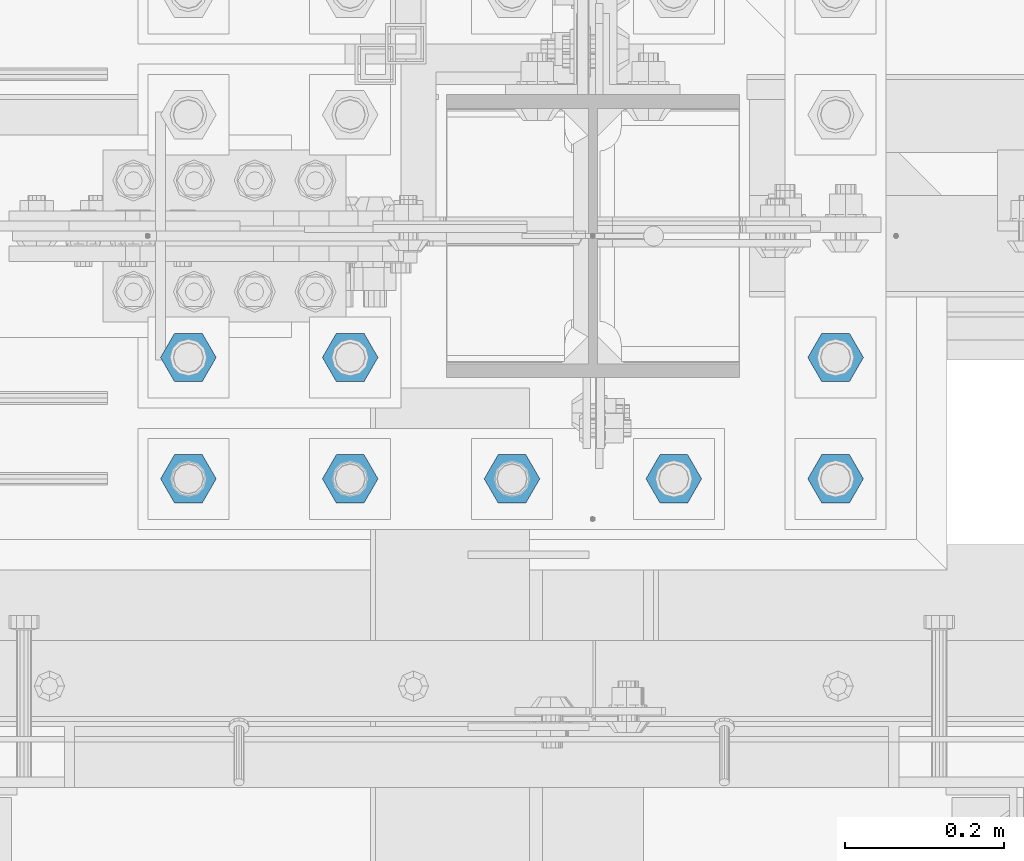
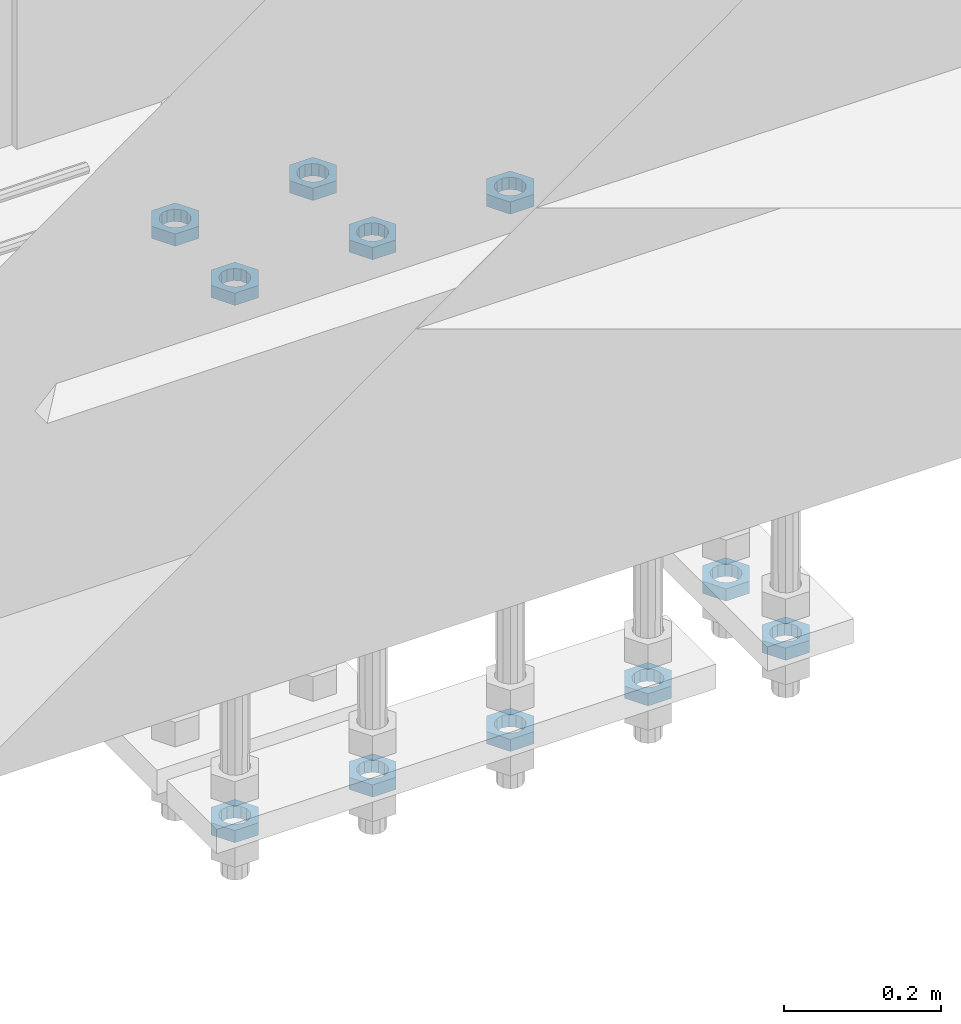
# One storey, part 2814 of 3843: 11 beams, 1 element without a shape of its own.
"""IFC2X3 building model written with IfcOpenShell, lengths in millimetres."""

from ifc_helpers import new_model, si_unit, frame, origin_with_axes, place, context, subcontext, project, spatial, faceted_brep, material, type_object, element, aggregate, save


model = new_model("IFC2X3")

# Units and contexts
model_context = context("Model", 3, precision=1e-05, world=origin_with_axes())
body_context = subcontext(model_context, "Body", "Model", "MODEL_VIEW")
ifc_project = project(units=[si_unit("LENGTHUNIT", "METRE", prefix="MILLI"), si_unit("AREAUNIT", "SQUARE_METRE"), si_unit("VOLUMEUNIT", "CUBIC_METRE"), si_unit("MASSUNIT", "GRAM", prefix="KILO"), si_unit("TIMEUNIT", "SECOND"), si_unit("PLANEANGLEUNIT", "RADIAN"), si_unit("SOLIDANGLEUNIT", "STERADIAN"), si_unit("THERMODYNAMICTEMPERATUREUNIT", "DEGREE_CELSIUS"), si_unit("LUMINOUSINTENSITYUNIT", "LUMEN")], contexts=[model_context])

# Site, building, storey
site_placement = place(None, origin_with_axes())
site = spatial("IfcSite", under=ifc_project, at=site_placement, CompositionType="ELEMENT")
building_placement = place(site_placement, origin_with_axes())
building = spatial("IfcBuilding", under=site, at=building_placement, Name="Undefined", CompositionType="ELEMENT")
storey_placement = place(building_placement, origin_with_axes())
storey = spatial("IfcBuildingStorey", under=building, at=storey_placement, Name="Undefined", CompositionType="ELEMENT", Elevation=0.0)

# Assembly, beams
assembly_placement = place(storey_placement, origin_with_axes())
assembly = element("IfcElementAssembly", 1, at=assembly_placement, inside=storey, Name="TEMPLATE", AssemblyPlace="NOTDEFINED", PredefinedType="RIGID_FRAME")
ifc_material = material(Name="STEEL/A572-50")
beam_type = type_object("IfcBeamType", Name="1-1/2_HALF_NUT", PredefinedType="NOTDEFINED")
beam_1_placement = place(assembly_placement, frame((48895.0, 25311.1, 29603.7), z_axis=(0.0, -1.0, 0.0), x_axis=(0.0, 0.0, -1.0)))
beam_1 = element("IfcBeam", 2, at=beam_1_placement, type_object=beam_type, material=ifc_material, Name="NUT", ObjectType="1-1/2_HALF_NUT", context=body_context, shape_type="Brep", body=[
    faceted_brep([(0.0, -34.9199981689453, 0.0), (0.0, -17.4599990844727, -30.25), (19.0500000000029, -17.4599990844727, -30.25), (19.0500000000029, -34.9199981689453, 0.0), (0.0, 17.4599990844727, -30.25), (19.0500000000029, 17.4599990844727, -30.25), (0.0, 34.9199981689453, 0.0), (19.0500000000029, 34.9199981689453, 0.0), (0.0, 17.4599990844727, 30.25), (19.0500000000029, 17.4599990844727, 30.25), (0.0, -17.4599990844727, 30.25), (19.0500000000029, -17.4599990844727, 30.25), (0.0, 0.0, 20.6399993896484), (0.0, 8.9553601105581, 18.5959968835959), (19.0500000000029, 8.95536011056538, 18.5959968835959), (19.0500000000029, 0.0, 20.6399993896484), (0.0, 16.1370013209525, 12.8688291298167), (19.0500000000029, 16.1370013209489, 12.8688291298167), (0.0, 20.1225115123816, 4.59283194104501), (19.0500000000029, 20.1225115123852, 4.59283194104501), (0.0, 20.1225115123816, -4.59283194104501), (19.0500000000029, 20.1225115123852, -4.59283194104501), (0.0, 16.1370013209525, -12.8688291298167), (19.0500000000029, 16.1370013209489, -12.8688291298167), (0.0, 8.9553601105581, -18.5959968835959), (19.0500000000029, 8.95536011056538, -18.5959968835959), (0.0, 0.0, -20.6399993896484), (19.0500000000029, 0.0, -20.6399993896484), (0.0, -8.9553601105581, -18.5959968835959), (19.0500000000029, -8.95536011056538, -18.5959968835959), (0.0, -16.1370013209525, -12.8688291298167), (19.0500000000029, -16.1370013209489, -12.8688291298167), (0.0, -20.1225115123816, -4.59283194104501), (19.0500000000029, -20.1225115123852, -4.59283194104501), (0.0, -20.1225115123816, 4.59283194104501), (19.0500000000029, -20.1225115123852, 4.59283194104501), (0.0, -16.1370013209525, 12.8688291298167), (19.0500000000029, -16.1370013209489, 12.8688291298167), (0.0, -8.9553601105581, 18.5959968835959), (19.0500000000029, -8.95536011056538, 18.5959968835959)], [[[0, 1, 2, 3]], [[1, 4, 5, 2]], [[4, 6, 7, 5]], [[6, 8, 9, 7]], [[8, 10, 11, 9]], [[10, 0, 3, 11]], [[12, 13, 14, 15]], [[13, 16, 17, 14]], [[16, 18, 19, 17]], [[18, 20, 21, 19]], [[20, 22, 23, 21]], [[22, 24, 25, 23]], [[24, 26, 27, 25]], [[26, 28, 29, 27]], [[28, 30, 31, 29]], [[30, 32, 33, 31]], [[32, 34, 35, 33]], [[34, 36, 37, 35]], [[36, 38, 39, 37]], [[38, 12, 15, 39]], [[5, 7, 9, 11, 3, 2], [17, 19, 21, 23, 25, 27, 29, 31, 33, 35, 37, 39, 15, 14]], [[10, 8, 6, 4, 1, 0], [38, 36, 34, 32, 30, 28, 26, 24, 22, 20, 18, 16, 13, 12]]]),
])
beam_2_placement = place(assembly_placement, frame((48691.8, 25463.5, 29603.7), z_axis=(0.0, -1.0, 0.0), x_axis=(0.0, 0.0, -1.0)))
beam_2 = element("IfcBeam", 3, at=beam_2_placement, type_object=beam_type, material=ifc_material, Name="NUT", ObjectType="1-1/2_HALF_NUT", context=body_context, shape_type="Brep", body=[
    faceted_brep([(0.0, -34.9199981689453, 0.0), (0.0, -17.4599990844727, -30.25), (19.0500000000029, -17.4599990844727, -30.25), (19.0500000000029, -34.9199981689453, 0.0), (0.0, 17.4599990844727, -30.25), (19.0500000000029, 17.4599990844727, -30.25), (0.0, 34.9199981689453, 0.0), (19.0500000000029, 34.9199981689453, 0.0), (0.0, 17.4599990844727, 30.25), (19.0500000000029, 17.4599990844727, 30.25), (0.0, -17.4599990844727, 30.25), (19.0500000000029, -17.4599990844727, 30.25), (0.0, 0.0, 20.6399993896484), (0.0, 8.9553601105581, 18.5959968835959), (19.0500000000029, 8.95536011056538, 18.5959968835959), (19.0500000000029, 0.0, 20.6399993896484), (0.0, 16.1370013209525, 12.8688291298167), (19.0500000000029, 16.1370013209489, 12.8688291298167), (0.0, 20.1225115123816, 4.59283194104501), (19.0500000000029, 20.1225115123852, 4.59283194104501), (0.0, 20.1225115123816, -4.59283194104501), (19.0500000000029, 20.1225115123852, -4.59283194104501), (0.0, 16.1370013209525, -12.8688291298167), (19.0500000000029, 16.1370013209489, -12.8688291298167), (0.0, 8.9553601105581, -18.5959968835959), (19.0500000000029, 8.95536011056538, -18.5959968835959), (0.0, 0.0, -20.6399993896484), (19.0500000000029, 0.0, -20.6399993896484), (0.0, -8.9553601105581, -18.5959968835959), (19.0500000000029, -8.95536011056538, -18.5959968835959), (0.0, -16.1370013209525, -12.8688291298167), (19.0500000000029, -16.1370013209489, -12.8688291298167), (0.0, -20.1225115123816, -4.59283194104501), (19.0500000000029, -20.1225115123852, -4.59283194104501), (0.0, -20.1225115123816, 4.59283194104501), (19.0500000000029, -20.1225115123852, 4.59283194104501), (0.0, -16.1370013209525, 12.8688291298167), (19.0500000000029, -16.1370013209489, 12.8688291298167), (0.0, -8.9553601105581, 18.5959968835959), (19.0500000000029, -8.95536011056538, 18.5959968835959)], [[[0, 1, 2, 3]], [[1, 4, 5, 2]], [[4, 6, 7, 5]], [[6, 8, 9, 7]], [[8, 10, 11, 9]], [[10, 0, 3, 11]], [[12, 13, 14, 15]], [[13, 16, 17, 14]], [[16, 18, 19, 17]], [[18, 20, 21, 19]], [[20, 22, 23, 21]], [[22, 24, 25, 23]], [[24, 26, 27, 25]], [[26, 28, 29, 27]], [[28, 30, 31, 29]], [[30, 32, 33, 31]], [[32, 34, 35, 33]], [[34, 36, 37, 35]], [[36, 38, 39, 37]], [[38, 12, 15, 39]], [[5, 7, 9, 11, 3, 2], [17, 19, 21, 23, 25, 27, 29, 31, 33, 35, 37, 39, 15, 14]], [[10, 8, 6, 4, 1, 0], [38, 36, 34, 32, 30, 28, 26, 24, 22, 20, 18, 16, 13, 12]]]),
])
beam_3_placement = place(assembly_placement, frame((48691.8, 25311.1, 29603.7), z_axis=(0.0, -1.0, 0.0), x_axis=(0.0, 0.0, -1.0)))
beam_3 = element("IfcBeam", 4, at=beam_3_placement, type_object=beam_type, material=ifc_material, Name="NUT", ObjectType="1-1/2_HALF_NUT", context=body_context, shape_type="Brep", body=[
    faceted_brep([(0.0, -34.9199981689453, 0.0), (0.0, -17.4599990844727, -30.25), (19.0500000000029, -17.4599990844727, -30.25), (19.0500000000029, -34.9199981689453, 0.0), (0.0, 17.4599990844727, -30.25), (19.0500000000029, 17.4599990844727, -30.25), (0.0, 34.9199981689453, 0.0), (19.0500000000029, 34.9199981689453, 0.0), (0.0, 17.4599990844727, 30.25), (19.0500000000029, 17.4599990844727, 30.25), (0.0, -17.4599990844727, 30.25), (19.0500000000029, -17.4599990844727, 30.25), (0.0, 0.0, 20.6399993896484), (0.0, 8.9553601105581, 18.5959968835959), (19.0500000000029, 8.95536011056538, 18.5959968835959), (19.0500000000029, 0.0, 20.6399993896484), (0.0, 16.1370013209525, 12.8688291298167), (19.0500000000029, 16.1370013209489, 12.8688291298167), (0.0, 20.1225115123816, 4.59283194104501), (19.0500000000029, 20.1225115123852, 4.59283194104501), (0.0, 20.1225115123816, -4.59283194104501), (19.0500000000029, 20.1225115123852, -4.59283194104501), (0.0, 16.1370013209525, -12.8688291298167), (19.0500000000029, 16.1370013209489, -12.8688291298167), (0.0, 8.9553601105581, -18.5959968835959), (19.0500000000029, 8.95536011056538, -18.5959968835959), (0.0, 0.0, -20.6399993896484), (19.0500000000029, 0.0, -20.6399993896484), (0.0, -8.9553601105581, -18.5959968835959), (19.0500000000029, -8.95536011056538, -18.5959968835959), (0.0, -16.1370013209525, -12.8688291298167), (19.0500000000029, -16.1370013209489, -12.8688291298167), (0.0, -20.1225115123816, -4.59283194104501), (19.0500000000029, -20.1225115123852, -4.59283194104501), (0.0, -20.1225115123816, 4.59283194104501), (19.0500000000029, -20.1225115123852, 4.59283194104501), (0.0, -16.1370013209525, 12.8688291298167), (19.0500000000029, -16.1370013209489, 12.8688291298167), (0.0, -8.9553601105581, 18.5959968835959), (19.0500000000029, -8.95536011056538, 18.5959968835959)], [[[0, 1, 2, 3]], [[1, 4, 5, 2]], [[4, 6, 7, 5]], [[6, 8, 9, 7]], [[8, 10, 11, 9]], [[10, 0, 3, 11]], [[12, 13, 14, 15]], [[13, 16, 17, 14]], [[16, 18, 19, 17]], [[18, 20, 21, 19]], [[20, 22, 23, 21]], [[22, 24, 25, 23]], [[24, 26, 27, 25]], [[26, 28, 29, 27]], [[28, 30, 31, 29]], [[30, 32, 33, 31]], [[32, 34, 35, 33]], [[34, 36, 37, 35]], [[36, 38, 39, 37]], [[38, 12, 15, 39]], [[5, 7, 9, 11, 3, 2], [17, 19, 21, 23, 25, 27, 29, 31, 33, 35, 37, 39, 15, 14]], [[10, 8, 6, 4, 1, 0], [38, 36, 34, 32, 30, 28, 26, 24, 22, 20, 18, 16, 13, 12]]]),
])
beam_4_placement = place(assembly_placement, frame((48488.6, 25463.5, 29603.7), z_axis=(0.0, -1.0, 0.0), x_axis=(0.0, 0.0, -1.0)))
beam_4 = element("IfcBeam", 5, at=beam_4_placement, type_object=beam_type, material=ifc_material, Name="NUT", ObjectType="1-1/2_HALF_NUT", context=body_context, shape_type="Brep", body=[
    faceted_brep([(0.0, -34.9199981689453, 0.0), (0.0, -17.4599990844727, -30.25), (19.0500000000029, -17.4599990844727, -30.25), (19.0500000000029, -34.9199981689453, 0.0), (0.0, 17.4599990844727, -30.25), (19.0500000000029, 17.4599990844727, -30.25), (0.0, 34.9199981689453, 0.0), (19.0500000000029, 34.9199981689453, 0.0), (0.0, 17.4599990844727, 30.25), (19.0500000000029, 17.4599990844727, 30.25), (0.0, -17.4599990844727, 30.25), (19.0500000000029, -17.4599990844727, 30.25), (0.0, 0.0, 20.6399993896484), (0.0, 8.9553601105581, 18.5959968835959), (19.0500000000029, 8.95536011056538, 18.5959968835959), (19.0500000000029, 0.0, 20.6399993896484), (0.0, 16.1370013209525, 12.8688291298167), (19.0500000000029, 16.1370013209489, 12.8688291298167), (0.0, 20.1225115123816, 4.59283194104501), (19.0500000000029, 20.1225115123852, 4.59283194104501), (0.0, 20.1225115123816, -4.59283194104501), (19.0500000000029, 20.1225115123852, -4.59283194104501), (0.0, 16.1370013209525, -12.8688291298167), (19.0500000000029, 16.1370013209489, -12.8688291298167), (0.0, 8.9553601105581, -18.5959968835959), (19.0500000000029, 8.95536011056538, -18.5959968835959), (0.0, 0.0, -20.6399993896484), (19.0500000000029, 0.0, -20.6399993896484), (0.0, -8.9553601105581, -18.5959968835959), (19.0500000000029, -8.95536011056538, -18.5959968835959), (0.0, -16.1370013209525, -12.8688291298167), (19.0500000000029, -16.1370013209489, -12.8688291298167), (0.0, -20.1225115123816, -4.59283194104501), (19.0500000000029, -20.1225115123852, -4.59283194104501), (0.0, -20.1225115123816, 4.59283194104501), (19.0500000000029, -20.1225115123852, 4.59283194104501), (0.0, -16.1370013209525, 12.8688291298167), (19.0500000000029, -16.1370013209489, 12.8688291298167), (0.0, -8.9553601105581, 18.5959968835959), (19.0500000000029, -8.95536011056538, 18.5959968835959)], [[[0, 1, 2, 3]], [[1, 4, 5, 2]], [[4, 6, 7, 5]], [[6, 8, 9, 7]], [[8, 10, 11, 9]], [[10, 0, 3, 11]], [[12, 13, 14, 15]], [[13, 16, 17, 14]], [[16, 18, 19, 17]], [[18, 20, 21, 19]], [[20, 22, 23, 21]], [[22, 24, 25, 23]], [[24, 26, 27, 25]], [[26, 28, 29, 27]], [[28, 30, 31, 29]], [[30, 32, 33, 31]], [[32, 34, 35, 33]], [[34, 36, 37, 35]], [[36, 38, 39, 37]], [[38, 12, 15, 39]], [[5, 7, 9, 11, 3, 2], [17, 19, 21, 23, 25, 27, 29, 31, 33, 35, 37, 39, 15, 14]], [[10, 8, 6, 4, 1, 0], [38, 36, 34, 32, 30, 28, 26, 24, 22, 20, 18, 16, 13, 12]]]),
])
beam_5_placement = place(assembly_placement, frame((48488.6, 25311.1, 29603.7), z_axis=(0.0, -1.0, 0.0), x_axis=(0.0, 0.0, -1.0)))
beam_5 = element("IfcBeam", 6, at=beam_5_placement, type_object=beam_type, material=ifc_material, Name="NUT", ObjectType="1-1/2_HALF_NUT", context=body_context, shape_type="Brep", body=[
    faceted_brep([(0.0, -34.9199981689453, 0.0), (0.0, -17.4599990844727, -30.25), (19.0500000000029, -17.4599990844727, -30.25), (19.0500000000029, -34.9199981689453, 0.0), (0.0, 17.4599990844727, -30.25), (19.0500000000029, 17.4599990844727, -30.25), (0.0, 34.9199981689453, 0.0), (19.0500000000029, 34.9199981689453, 0.0), (0.0, 17.4599990844727, 30.25), (19.0500000000029, 17.4599990844727, 30.25), (0.0, -17.4599990844727, 30.25), (19.0500000000029, -17.4599990844727, 30.25), (0.0, 0.0, 20.6399993896484), (0.0, 8.9553601105581, 18.5959968835959), (19.0500000000029, 8.95536011056538, 18.5959968835959), (19.0500000000029, 0.0, 20.6399993896484), (0.0, 16.1370013209525, 12.8688291298167), (19.0500000000029, 16.1370013209489, 12.8688291298167), (0.0, 20.1225115123816, 4.59283194104501), (19.0500000000029, 20.1225115123852, 4.59283194104501), (0.0, 20.1225115123816, -4.59283194104501), (19.0500000000029, 20.1225115123852, -4.59283194104501), (0.0, 16.1370013209525, -12.8688291298167), (19.0500000000029, 16.1370013209489, -12.8688291298167), (0.0, 8.9553601105581, -18.5959968835959), (19.0500000000029, 8.95536011056538, -18.5959968835959), (0.0, 0.0, -20.6399993896484), (19.0500000000029, 0.0, -20.6399993896484), (0.0, -8.9553601105581, -18.5959968835959), (19.0500000000029, -8.95536011056538, -18.5959968835959), (0.0, -16.1370013209525, -12.8688291298167), (19.0500000000029, -16.1370013209489, -12.8688291298167), (0.0, -20.1225115123816, -4.59283194104501), (19.0500000000029, -20.1225115123852, -4.59283194104501), (0.0, -20.1225115123816, 4.59283194104501), (19.0500000000029, -20.1225115123852, 4.59283194104501), (0.0, -16.1370013209525, 12.8688291298167), (19.0500000000029, -16.1370013209489, 12.8688291298167), (0.0, -8.9553601105581, 18.5959968835959), (19.0500000000029, -8.95536011056538, 18.5959968835959)], [[[0, 1, 2, 3]], [[1, 4, 5, 2]], [[4, 6, 7, 5]], [[6, 8, 9, 7]], [[8, 10, 11, 9]], [[10, 0, 3, 11]], [[12, 13, 14, 15]], [[13, 16, 17, 14]], [[16, 18, 19, 17]], [[18, 20, 21, 19]], [[20, 22, 23, 21]], [[22, 24, 25, 23]], [[24, 26, 27, 25]], [[26, 28, 29, 27]], [[28, 30, 31, 29]], [[30, 32, 33, 31]], [[32, 34, 35, 33]], [[34, 36, 37, 35]], [[36, 38, 39, 37]], [[38, 12, 15, 39]], [[5, 7, 9, 11, 3, 2], [17, 19, 21, 23, 25, 27, 29, 31, 33, 35, 37, 39, 15, 14]], [[10, 8, 6, 4, 1, 0], [38, 36, 34, 32, 30, 28, 26, 24, 22, 20, 18, 16, 13, 12]]]),
])
beam_6_placement = place(assembly_placement, frame((49301.4, 25311.1, 28765.5), z_axis=(0.0, -1.0, 0.0), x_axis=(0.0, 0.0, -1.0)))
beam_6 = element("IfcBeam", 7, at=beam_6_placement, type_object=beam_type, material=ifc_material, Name="NUT", ObjectType="1-1/2_HALF_NUT", context=body_context, shape_type="Brep", body=[
    faceted_brep([(0.0, -34.9199981689453, 0.0), (0.0, -17.4599990844727, -30.25), (19.0500000000029, -17.4599990844727, -30.25), (19.0500000000029, -34.9199981689453, 0.0), (0.0, 17.4599990844727, -30.25), (19.0500000000029, 17.4599990844727, -30.25), (0.0, 34.9199981689453, 0.0), (19.0500000000029, 34.9199981689453, 0.0), (0.0, 17.4599990844727, 30.25), (19.0500000000029, 17.4599990844727, 30.25), (0.0, -17.4599990844727, 30.25), (19.0500000000029, -17.4599990844727, 30.25), (0.0, 0.0, 20.6399993896484), (0.0, 8.9553601105581, 18.5959968835959), (19.0500000000029, 8.95536011056538, 18.5959968835959), (19.0500000000029, 0.0, 20.6399993896484), (0.0, 16.1370013209525, 12.8688291298167), (19.0500000000029, 16.1370013209489, 12.8688291298167), (0.0, 20.1225115123816, 4.59283194104501), (19.0500000000029, 20.1225115123852, 4.59283194104501), (0.0, 20.1225115123816, -4.59283194104501), (19.0500000000029, 20.1225115123852, -4.59283194104501), (0.0, 16.1370013209525, -12.8688291298167), (19.0500000000029, 16.1370013209489, -12.8688291298167), (0.0, 8.9553601105581, -18.5959968835959), (19.0500000000029, 8.95536011056538, -18.5959968835959), (0.0, 0.0, -20.6399993896484), (19.0500000000029, 0.0, -20.6399993896484), (0.0, -8.9553601105581, -18.5959968835959), (19.0500000000029, -8.95536011056538, -18.5959968835959), (0.0, -16.1370013209525, -12.8688291298167), (19.0500000000029, -16.1370013209489, -12.8688291298167), (0.0, -20.1225115123816, -4.59283194104501), (19.0500000000029, -20.1225115123852, -4.59283194104501), (0.0, -20.1225115123816, 4.59283194104501), (19.0500000000029, -20.1225115123852, 4.59283194104501), (0.0, -16.1370013209525, 12.8688291298167), (19.0500000000029, -16.1370013209489, 12.8688291298167), (0.0, -8.9553601105581, 18.5959968835959), (19.0500000000029, -8.95536011056538, 18.5959968835959)], [[[0, 1, 2, 3]], [[1, 4, 5, 2]], [[4, 6, 7, 5]], [[6, 8, 9, 7]], [[8, 10, 11, 9]], [[10, 0, 3, 11]], [[12, 13, 14, 15]], [[13, 16, 17, 14]], [[16, 18, 19, 17]], [[18, 20, 21, 19]], [[20, 22, 23, 21]], [[22, 24, 25, 23]], [[24, 26, 27, 25]], [[26, 28, 29, 27]], [[28, 30, 31, 29]], [[30, 32, 33, 31]], [[32, 34, 35, 33]], [[34, 36, 37, 35]], [[36, 38, 39, 37]], [[38, 12, 15, 39]], [[5, 7, 9, 11, 3, 2], [17, 19, 21, 23, 25, 27, 29, 31, 33, 35, 37, 39, 15, 14]], [[10, 8, 6, 4, 1, 0], [38, 36, 34, 32, 30, 28, 26, 24, 22, 20, 18, 16, 13, 12]]]),
])
beam_7_placement = place(assembly_placement, frame((49098.2, 25311.1, 28765.5), z_axis=(0.0, -1.0, 0.0), x_axis=(0.0, 0.0, -1.0)))
beam_7 = element("IfcBeam", 8, at=beam_7_placement, type_object=beam_type, material=ifc_material, Name="NUT", ObjectType="1-1/2_HALF_NUT", context=body_context, shape_type="Brep", body=[
    faceted_brep([(0.0, -34.9199981689453, 0.0), (0.0, -17.4599990844727, -30.25), (19.0500000000029, -17.4599990844727, -30.25), (19.0500000000029, -34.9199981689453, 0.0), (0.0, 17.4599990844727, -30.25), (19.0500000000029, 17.4599990844727, -30.25), (0.0, 34.9199981689453, 0.0), (19.0500000000029, 34.9199981689453, 0.0), (0.0, 17.4599990844727, 30.25), (19.0500000000029, 17.4599990844727, 30.25), (0.0, -17.4599990844727, 30.25), (19.0500000000029, -17.4599990844727, 30.25), (0.0, 0.0, 20.6399993896484), (0.0, 8.9553601105581, 18.5959968835959), (19.0500000000029, 8.95536011056538, 18.5959968835959), (19.0500000000029, 0.0, 20.6399993896484), (0.0, 16.1370013209525, 12.8688291298167), (19.0500000000029, 16.1370013209489, 12.8688291298167), (0.0, 20.1225115123816, 4.59283194104501), (19.0500000000029, 20.1225115123852, 4.59283194104501), (0.0, 20.1225115123816, -4.59283194104501), (19.0500000000029, 20.1225115123852, -4.59283194104501), (0.0, 16.1370013209525, -12.8688291298167), (19.0500000000029, 16.1370013209489, -12.8688291298167), (0.0, 8.9553601105581, -18.5959968835959), (19.0500000000029, 8.95536011056538, -18.5959968835959), (0.0, 0.0, -20.6399993896484), (19.0500000000029, 0.0, -20.6399993896484), (0.0, -8.9553601105581, -18.5959968835959), (19.0500000000029, -8.95536011056538, -18.5959968835959), (0.0, -16.1370013209525, -12.8688291298167), (19.0500000000029, -16.1370013209489, -12.8688291298167), (0.0, -20.1225115123816, -4.59283194104501), (19.0500000000029, -20.1225115123852, -4.59283194104501), (0.0, -20.1225115123816, 4.59283194104501), (19.0500000000029, -20.1225115123852, 4.59283194104501), (0.0, -16.1370013209525, 12.8688291298167), (19.0500000000029, -16.1370013209489, 12.8688291298167), (0.0, -8.9553601105581, 18.5959968835959), (19.0500000000029, -8.95536011056538, 18.5959968835959)], [[[0, 1, 2, 3]], [[1, 4, 5, 2]], [[4, 6, 7, 5]], [[6, 8, 9, 7]], [[8, 10, 11, 9]], [[10, 0, 3, 11]], [[12, 13, 14, 15]], [[13, 16, 17, 14]], [[16, 18, 19, 17]], [[18, 20, 21, 19]], [[20, 22, 23, 21]], [[22, 24, 25, 23]], [[24, 26, 27, 25]], [[26, 28, 29, 27]], [[28, 30, 31, 29]], [[30, 32, 33, 31]], [[32, 34, 35, 33]], [[34, 36, 37, 35]], [[36, 38, 39, 37]], [[38, 12, 15, 39]], [[5, 7, 9, 11, 3, 2], [17, 19, 21, 23, 25, 27, 29, 31, 33, 35, 37, 39, 15, 14]], [[10, 8, 6, 4, 1, 0], [38, 36, 34, 32, 30, 28, 26, 24, 22, 20, 18, 16, 13, 12]]]),
])
beam_8_placement = place(assembly_placement, frame((48895.0, 25311.1, 28765.5), z_axis=(0.0, -1.0, 0.0), x_axis=(0.0, 0.0, -1.0)))
beam_8 = element("IfcBeam", 9, at=beam_8_placement, type_object=beam_type, material=ifc_material, Name="NUT", ObjectType="1-1/2_HALF_NUT", context=body_context, shape_type="Brep", body=[
    faceted_brep([(0.0, -34.9199981689453, 0.0), (0.0, -17.4599990844727, -30.25), (19.0500000000029, -17.4599990844727, -30.25), (19.0500000000029, -34.9199981689453, 0.0), (0.0, 17.4599990844727, -30.25), (19.0500000000029, 17.4599990844727, -30.25), (0.0, 34.9199981689453, 0.0), (19.0500000000029, 34.9199981689453, 0.0), (0.0, 17.4599990844727, 30.25), (19.0500000000029, 17.4599990844727, 30.25), (0.0, -17.4599990844727, 30.25), (19.0500000000029, -17.4599990844727, 30.25), (0.0, 0.0, 20.6399993896484), (0.0, 8.9553601105581, 18.5959968835959), (19.0500000000029, 8.95536011056538, 18.5959968835959), (19.0500000000029, 0.0, 20.6399993896484), (0.0, 16.1370013209525, 12.8688291298167), (19.0500000000029, 16.1370013209489, 12.8688291298167), (0.0, 20.1225115123816, 4.59283194104501), (19.0500000000029, 20.1225115123852, 4.59283194104501), (0.0, 20.1225115123816, -4.59283194104501), (19.0500000000029, 20.1225115123852, -4.59283194104501), (0.0, 16.1370013209525, -12.8688291298167), (19.0500000000029, 16.1370013209489, -12.8688291298167), (0.0, 8.9553601105581, -18.5959968835959), (19.0500000000029, 8.95536011056538, -18.5959968835959), (0.0, 0.0, -20.6399993896484), (19.0500000000029, 0.0, -20.6399993896484), (0.0, -8.9553601105581, -18.5959968835959), (19.0500000000029, -8.95536011056538, -18.5959968835959), (0.0, -16.1370013209525, -12.8688291298167), (19.0500000000029, -16.1370013209489, -12.8688291298167), (0.0, -20.1225115123816, -4.59283194104501), (19.0500000000029, -20.1225115123852, -4.59283194104501), (0.0, -20.1225115123816, 4.59283194104501), (19.0500000000029, -20.1225115123852, 4.59283194104501), (0.0, -16.1370013209525, 12.8688291298167), (19.0500000000029, -16.1370013209489, 12.8688291298167), (0.0, -8.9553601105581, 18.5959968835959), (19.0500000000029, -8.95536011056538, 18.5959968835959)], [[[0, 1, 2, 3]], [[1, 4, 5, 2]], [[4, 6, 7, 5]], [[6, 8, 9, 7]], [[8, 10, 11, 9]], [[10, 0, 3, 11]], [[12, 13, 14, 15]], [[13, 16, 17, 14]], [[16, 18, 19, 17]], [[18, 20, 21, 19]], [[20, 22, 23, 21]], [[22, 24, 25, 23]], [[24, 26, 27, 25]], [[26, 28, 29, 27]], [[28, 30, 31, 29]], [[30, 32, 33, 31]], [[32, 34, 35, 33]], [[34, 36, 37, 35]], [[36, 38, 39, 37]], [[38, 12, 15, 39]], [[5, 7, 9, 11, 3, 2], [17, 19, 21, 23, 25, 27, 29, 31, 33, 35, 37, 39, 15, 14]], [[10, 8, 6, 4, 1, 0], [38, 36, 34, 32, 30, 28, 26, 24, 22, 20, 18, 16, 13, 12]]]),
])
beam_9_placement = place(assembly_placement, frame((48691.8, 25311.1, 28765.5), z_axis=(0.0, 1.0, 0.0), x_axis=(0.0, 0.0, -1.0)))
beam_9 = element("IfcBeam", 10, at=beam_9_placement, type_object=beam_type, material=ifc_material, Name="NUT", ObjectType="1-1/2_HALF_NUT", context=body_context, shape_type="Brep", body=[
    faceted_brep([(0.0, -34.9199981689453, 0.0), (0.0, -17.4599990844727, -30.25), (19.0500000000029, -17.4599990844727, -30.25), (19.0500000000029, -34.9199981689453, 0.0), (0.0, 17.4599990844727, -30.25), (19.0500000000029, 17.4599990844727, -30.25), (0.0, 34.9199981689453, 0.0), (19.0500000000029, 34.9199981689453, 0.0), (0.0, 17.4599990844727, 30.25), (19.0500000000029, 17.4599990844727, 30.25), (0.0, -17.4599990844727, 30.25), (19.0500000000029, -17.4599990844727, 30.25), (0.0, 0.0, 20.6399993896484), (0.0, 8.9553601105581, 18.5959968835959), (19.0500000000029, 8.95536011056538, 18.5959968835959), (19.0500000000029, 0.0, 20.6399993896484), (0.0, 16.1370013209525, 12.8688291298167), (19.0500000000029, 16.1370013209489, 12.8688291298167), (0.0, 20.1225115123816, 4.59283194104501), (19.0500000000029, 20.1225115123852, 4.59283194104501), (0.0, 20.1225115123816, -4.59283194104501), (19.0500000000029, 20.1225115123852, -4.59283194104501), (0.0, 16.1370013209525, -12.8688291298167), (19.0500000000029, 16.1370013209489, -12.8688291298167), (0.0, 8.9553601105581, -18.5959968835959), (19.0500000000029, 8.95536011056538, -18.5959968835959), (0.0, 0.0, -20.6399993896484), (19.0500000000029, 0.0, -20.6399993896484), (0.0, -8.9553601105581, -18.5959968835959), (19.0500000000029, -8.95536011056538, -18.5959968835959), (0.0, -16.1370013209525, -12.8688291298167), (19.0500000000029, -16.1370013209489, -12.8688291298167), (0.0, -20.1225115123816, -4.59283194104501), (19.0500000000029, -20.1225115123852, -4.59283194104501), (0.0, -20.1225115123816, 4.59283194104501), (19.0500000000029, -20.1225115123852, 4.59283194104501), (0.0, -16.1370013209525, 12.8688291298167), (19.0500000000029, -16.1370013209489, 12.8688291298167), (0.0, -8.9553601105581, 18.5959968835959), (19.0500000000029, -8.95536011056538, 18.5959968835959)], [[[0, 1, 2, 3]], [[1, 4, 5, 2]], [[4, 6, 7, 5]], [[6, 8, 9, 7]], [[8, 10, 11, 9]], [[10, 0, 3, 11]], [[12, 13, 14, 15]], [[13, 16, 17, 14]], [[16, 18, 19, 17]], [[18, 20, 21, 19]], [[20, 22, 23, 21]], [[22, 24, 25, 23]], [[24, 26, 27, 25]], [[26, 28, 29, 27]], [[28, 30, 31, 29]], [[30, 32, 33, 31]], [[32, 34, 35, 33]], [[34, 36, 37, 35]], [[36, 38, 39, 37]], [[38, 12, 15, 39]], [[5, 7, 9, 11, 3, 2], [17, 19, 21, 23, 25, 27, 29, 31, 33, 35, 37, 39, 15, 14]], [[10, 8, 6, 4, 1, 0], [38, 36, 34, 32, 30, 28, 26, 24, 22, 20, 18, 16, 13, 12]]]),
])
beam_10_placement = place(assembly_placement, frame((48488.599974823, 25311.1, 28765.5), z_axis=(0.0, 1.0, 0.0), x_axis=(0.0, 0.0, -1.0)))
beam_10 = element("IfcBeam", 11, at=beam_10_placement, type_object=beam_type, material=ifc_material, Name="NUT", ObjectType="1-1/2_HALF_NUT", context=body_context, shape_type="Brep", body=[
    faceted_brep([(0.0, -34.9199981689453, 0.0), (0.0, -17.4599990844727, -30.25), (19.0500000000029, -17.4599990844727, -30.25), (19.0500000000029, -34.9199981689453, 0.0), (0.0, 17.4599990844727, -30.25), (19.0500000000029, 17.4599990844727, -30.25), (0.0, 34.9199981689453, 0.0), (19.0500000000029, 34.9199981689453, 0.0), (0.0, 17.4599990844727, 30.25), (19.0500000000029, 17.4599990844727, 30.25), (0.0, -17.4599990844727, 30.25), (19.0500000000029, -17.4599990844727, 30.25), (0.0, 0.0, 20.6399993896484), (0.0, 8.9553601105581, 18.5959968835959), (19.0500000000029, 8.95536011056538, 18.5959968835959), (19.0500000000029, 0.0, 20.6399993896484), (0.0, 16.1370013209525, 12.8688291298167), (19.0500000000029, 16.1370013209489, 12.8688291298167), (0.0, 20.1225115123816, 4.59283194104501), (19.0500000000029, 20.1225115123852, 4.59283194104501), (0.0, 20.1225115123816, -4.59283194104501), (19.0500000000029, 20.1225115123852, -4.59283194104501), (0.0, 16.1370013209525, -12.8688291298167), (19.0500000000029, 16.1370013209489, -12.8688291298167), (0.0, 8.9553601105581, -18.5959968835959), (19.0500000000029, 8.95536011056538, -18.5959968835959), (0.0, 0.0, -20.6399993896484), (19.0500000000029, 0.0, -20.6399993896484), (0.0, -8.9553601105581, -18.5959968835959), (19.0500000000029, -8.95536011056538, -18.5959968835959), (0.0, -16.1370013209525, -12.8688291298167), (19.0500000000029, -16.1370013209489, -12.8688291298167), (0.0, -20.1225115123816, -4.59283194104501), (19.0500000000029, -20.1225115123852, -4.59283194104501), (0.0, -20.1225115123816, 4.59283194104501), (19.0500000000029, -20.1225115123852, 4.59283194104501), (0.0, -16.1370013209525, 12.8688291298167), (19.0500000000029, -16.1370013209489, 12.8688291298167), (0.0, -8.9553601105581, 18.5959968835959), (19.0500000000029, -8.95536011056538, 18.5959968835959)], [[[0, 1, 2, 3]], [[1, 4, 5, 2]], [[4, 6, 7, 5]], [[6, 8, 9, 7]], [[8, 10, 11, 9]], [[10, 0, 3, 11]], [[12, 13, 14, 15]], [[13, 16, 17, 14]], [[16, 18, 19, 17]], [[18, 20, 21, 19]], [[20, 22, 23, 21]], [[22, 24, 25, 23]], [[24, 26, 27, 25]], [[26, 28, 29, 27]], [[28, 30, 31, 29]], [[30, 32, 33, 31]], [[32, 34, 35, 33]], [[34, 36, 37, 35]], [[36, 38, 39, 37]], [[38, 12, 15, 39]], [[5, 7, 9, 11, 3, 2], [17, 19, 21, 23, 25, 27, 29, 31, 33, 35, 37, 39, 15, 14]], [[10, 8, 6, 4, 1, 0], [38, 36, 34, 32, 30, 28, 26, 24, 22, 20, 18, 16, 13, 12]]]),
])
beam_11_placement = place(assembly_placement, frame((49301.4, 25463.5, 28765.5), z_axis=(0.0, -1.0, 0.0), x_axis=(0.0, 0.0, -1.0)))
beam_11 = element("IfcBeam", 12, at=beam_11_placement, type_object=beam_type, material=ifc_material, Name="NUT", ObjectType="1-1/2_HALF_NUT", context=body_context, shape_type="Brep", body=[
    faceted_brep([(0.0, -34.9199981689453, 0.0), (0.0, -17.4599990844727, -30.25), (19.0500000000029, -17.4599990844727, -30.25), (19.0500000000029, -34.9199981689453, 0.0), (0.0, 17.4599990844727, -30.25), (19.0500000000029, 17.4599990844727, -30.25), (0.0, 34.9199981689453, 0.0), (19.0500000000029, 34.9199981689453, 0.0), (0.0, 17.4599990844727, 30.25), (19.0500000000029, 17.4599990844727, 30.25), (0.0, -17.4599990844727, 30.25), (19.0500000000029, -17.4599990844727, 30.25), (0.0, 0.0, 20.6399993896484), (0.0, 8.9553601105581, 18.5959968835959), (19.0500000000029, 8.95536011056538, 18.5959968835959), (19.0500000000029, 0.0, 20.6399993896484), (0.0, 16.1370013209525, 12.8688291298167), (19.0500000000029, 16.1370013209489, 12.8688291298167), (0.0, 20.1225115123816, 4.59283194104501), (19.0500000000029, 20.1225115123852, 4.59283194104501), (0.0, 20.1225115123816, -4.59283194104501), (19.0500000000029, 20.1225115123852, -4.59283194104501), (0.0, 16.1370013209525, -12.8688291298167), (19.0500000000029, 16.1370013209489, -12.8688291298167), (0.0, 8.9553601105581, -18.5959968835959), (19.0500000000029, 8.95536011056538, -18.5959968835959), (0.0, 0.0, -20.6399993896484), (19.0500000000029, 0.0, -20.6399993896484), (0.0, -8.9553601105581, -18.5959968835959), (19.0500000000029, -8.95536011056538, -18.5959968835959), (0.0, -16.1370013209525, -12.8688291298167), (19.0500000000029, -16.1370013209489, -12.8688291298167), (0.0, -20.1225115123816, -4.59283194104501), (19.0500000000029, -20.1225115123852, -4.59283194104501), (0.0, -20.1225115123816, 4.59283194104501), (19.0500000000029, -20.1225115123852, 4.59283194104501), (0.0, -16.1370013209525, 12.8688291298167), (19.0500000000029, -16.1370013209489, 12.8688291298167), (0.0, -8.9553601105581, 18.5959968835959), (19.0500000000029, -8.95536011056538, 18.5959968835959)], [[[0, 1, 2, 3]], [[1, 4, 5, 2]], [[4, 6, 7, 5]], [[6, 8, 9, 7]], [[8, 10, 11, 9]], [[10, 0, 3, 11]], [[12, 13, 14, 15]], [[13, 16, 17, 14]], [[16, 18, 19, 17]], [[18, 20, 21, 19]], [[20, 22, 23, 21]], [[22, 24, 25, 23]], [[24, 26, 27, 25]], [[26, 28, 29, 27]], [[28, 30, 31, 29]], [[30, 32, 33, 31]], [[32, 34, 35, 33]], [[34, 36, 37, 35]], [[36, 38, 39, 37]], [[38, 12, 15, 39]], [[5, 7, 9, 11, 3, 2], [17, 19, 21, 23, 25, 27, 29, 31, 33, 35, 37, 39, 15, 14]], [[10, 8, 6, 4, 1, 0], [38, 36, 34, 32, 30, 28, 26, 24, 22, 20, 18, 16, 13, 12]]]),
])
aggregate(assembly, [beam_1, beam_2, beam_3, beam_4, beam_5, beam_6, beam_7, beam_8, beam_9, beam_10, beam_11])

save(model, "model.ifc")
